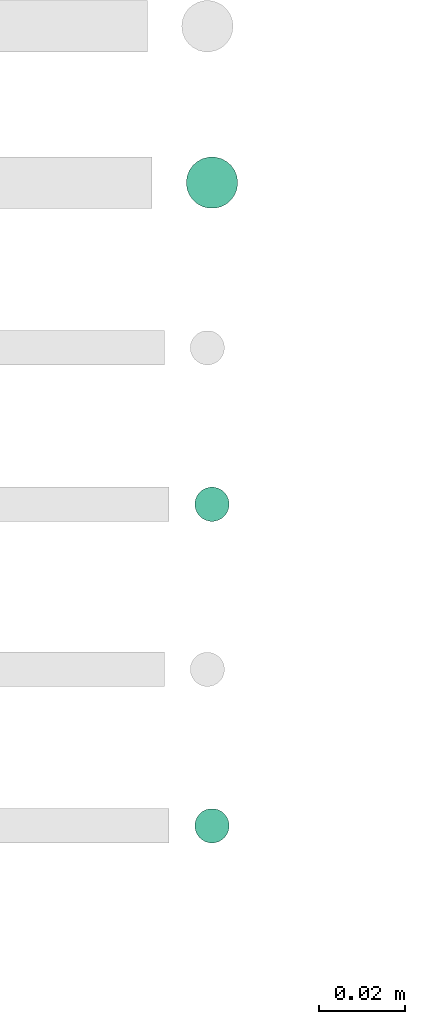
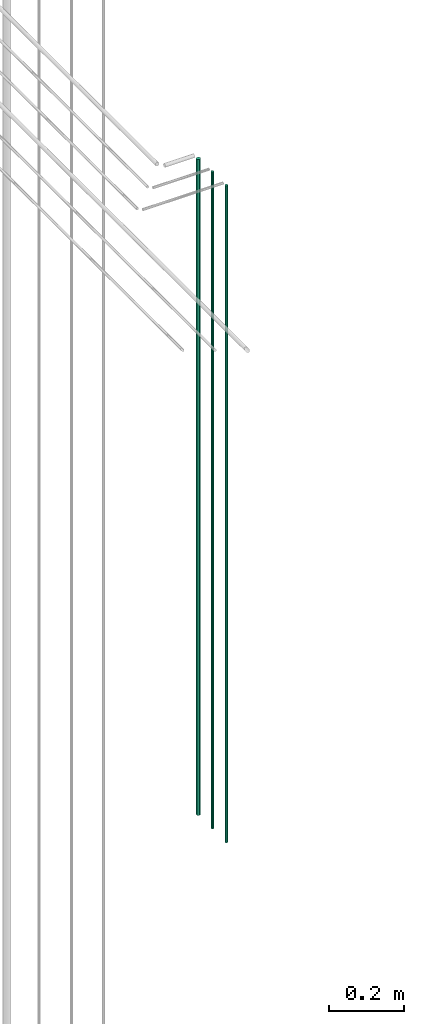
# One storey, part 72 of 331: 3 flow segments.
"""IFC2X3 building model written with IfcOpenShell, lengths in millimetres."""

from ifc_helpers import new_model, entity, si_unit, converted_unit, derived_unit, direction, frame, origin, origin_2d_with_axis, place, context, subcontext, project, spatial, circle, extrude, type_object, element, save


model = new_model("IFC2X3")

# Units and contexts
model_context = context("Model", 3, precision=0.01, world=origin(), true_north=direction((6.12303176911189e-17, 1.0)))
body_context = subcontext(model_context, "Body", "Model", "MODEL_VIEW")
ifc_project = project(units=[si_unit("LENGTHUNIT", "METRE", prefix="MILLI"), si_unit("AREAUNIT", "SQUARE_METRE"), si_unit("VOLUMEUNIT", "CUBIC_METRE"), converted_unit("PLANEANGLEUNIT", "DEGREE", entity("IfcRatioMeasure", 0.0174532925199433), si_unit("PLANEANGLEUNIT", "RADIAN"), dimensions=[0, 0, 0, 0, 0, 0, 0]), si_unit("MASSUNIT", "GRAM", prefix="KILO"), derived_unit("MASSDENSITYUNIT", [(si_unit("MASSUNIT", "GRAM", prefix="KILO"), 1), (si_unit("LENGTHUNIT", "METRE"), -3)]), derived_unit("MOMENTOFINERTIAUNIT", [(si_unit("LENGTHUNIT", "METRE"), 4)]), si_unit("TIMEUNIT", "SECOND"), si_unit("FREQUENCYUNIT", "HERTZ"), si_unit("THERMODYNAMICTEMPERATUREUNIT", "DEGREE_CELSIUS"), derived_unit("THERMALTRANSMITTANCEUNIT", [(si_unit("MASSUNIT", "GRAM", prefix="KILO"), 1), (si_unit("THERMODYNAMICTEMPERATUREUNIT", "KELVIN"), -1), (si_unit("TIMEUNIT", "SECOND"), -3)]), derived_unit("VOLUMETRICFLOWRATEUNIT", [(si_unit("LENGTHUNIT", "METRE"), 3), (si_unit("TIMEUNIT", "SECOND"), -1)]), derived_unit("MASSFLOWRATEUNIT", [(si_unit("MASSUNIT", "GRAM", prefix="KILO"), 1), (si_unit("TIMEUNIT", "SECOND"), -1)]), derived_unit("ROTATIONALFREQUENCYUNIT", [(si_unit("TIMEUNIT", "SECOND"), -1)]), si_unit("ELECTRICCURRENTUNIT", "AMPERE"), si_unit("ELECTRICVOLTAGEUNIT", "VOLT"), si_unit("POWERUNIT", "WATT"), si_unit("FORCEUNIT", "NEWTON", prefix="KILO"), si_unit("ILLUMINANCEUNIT", "LUX"), si_unit("LUMINOUSFLUXUNIT", "LUMEN"), si_unit("LUMINOUSINTENSITYUNIT", "CANDELA"), derived_unit("USERDEFINED", [(si_unit("MASSUNIT", "GRAM", prefix="KILO"), -1), (si_unit("LENGTHUNIT", "METRE"), -2), (si_unit("TIMEUNIT", "SECOND"), 3), (si_unit("LUMINOUSFLUXUNIT", "LUMEN"), 1)]), derived_unit("LINEARVELOCITYUNIT", [(si_unit("LENGTHUNIT", "METRE"), 1), (si_unit("TIMEUNIT", "SECOND"), -1)]), si_unit("PRESSUREUNIT", "PASCAL"), derived_unit("USERDEFINED", [(si_unit("LENGTHUNIT", "METRE"), -2), (si_unit("MASSUNIT", "GRAM", prefix="KILO"), 1), (si_unit("TIMEUNIT", "SECOND"), -2)]), derived_unit("LINEARFORCEUNIT", [(si_unit("MASSUNIT", "GRAM", prefix="KILO"), 1), (si_unit("LENGTHUNIT", "METRE"), 1), (si_unit("TIMEUNIT", "SECOND"), -2), (si_unit("LENGTHUNIT", "METRE"), -1)]), derived_unit("PLANARFORCEUNIT", [(si_unit("MASSUNIT", "GRAM", prefix="KILO"), 1), (si_unit("LENGTHUNIT", "METRE"), 1), (si_unit("TIMEUNIT", "SECOND"), -2), (si_unit("LENGTHUNIT", "METRE"), -2)])], contexts=[model_context])

# Site, building, storey
site_placement = place(None, frame((0.0, -0.00077364408347762, 0.0)))
site = spatial("IfcSite", under=ifc_project, at=site_placement, CompositionType="ELEMENT")
building_placement = place(site_placement, origin())
building = spatial("IfcBuilding", under=site, at=building_placement, CompositionType="ELEMENT")
storey_placement = place(building_placement, origin())
storey = spatial("IfcBuildingStorey", under=building, at=storey_placement, CompositionType="ELEMENT", Elevation=0.0)

# Flow segments
pipe_segment_type = type_object("IfcPipeSegmentType", PredefinedType="NOTDEFINED")
flow_segment_placement = place(storey_placement, frame((62357.9067248113, 3847.40472776424, 12990.0)))
element("IfcFlowSegment", 1, at=flow_segment_placement, inside=storey, type_object=pipe_segment_type, context=body_context, shape_type="SweptSolid", body=[
    extrude(circle(Radius=6.0, at=origin_2d_with_axis()), frame((7.59527223591454, 7.59527223591616, 0.0)), (0.0, 0.0, 1.0), 2146.0),
])
for number, where in (
    (2, (62359.9067248113, 3699.40472776424, 12990.0)),
    (3, (62359.9067248113, 3774.40472776425, 12990.0)),
):
    element("IfcFlowSegment", number, at=place(storey_placement, frame(where)), inside=storey, type_object=pipe_segment_type, context=body_context, shape_type="SweptSolid", body=[
        extrude(circle(Radius=4.0, at=origin_2d_with_axis()), frame((5.59527223591499, 5.59527223591607, 0.0)), (0.0, 0.0, 1.0), 2150.00000000001),
    ])

save(model, "model.ifc")
